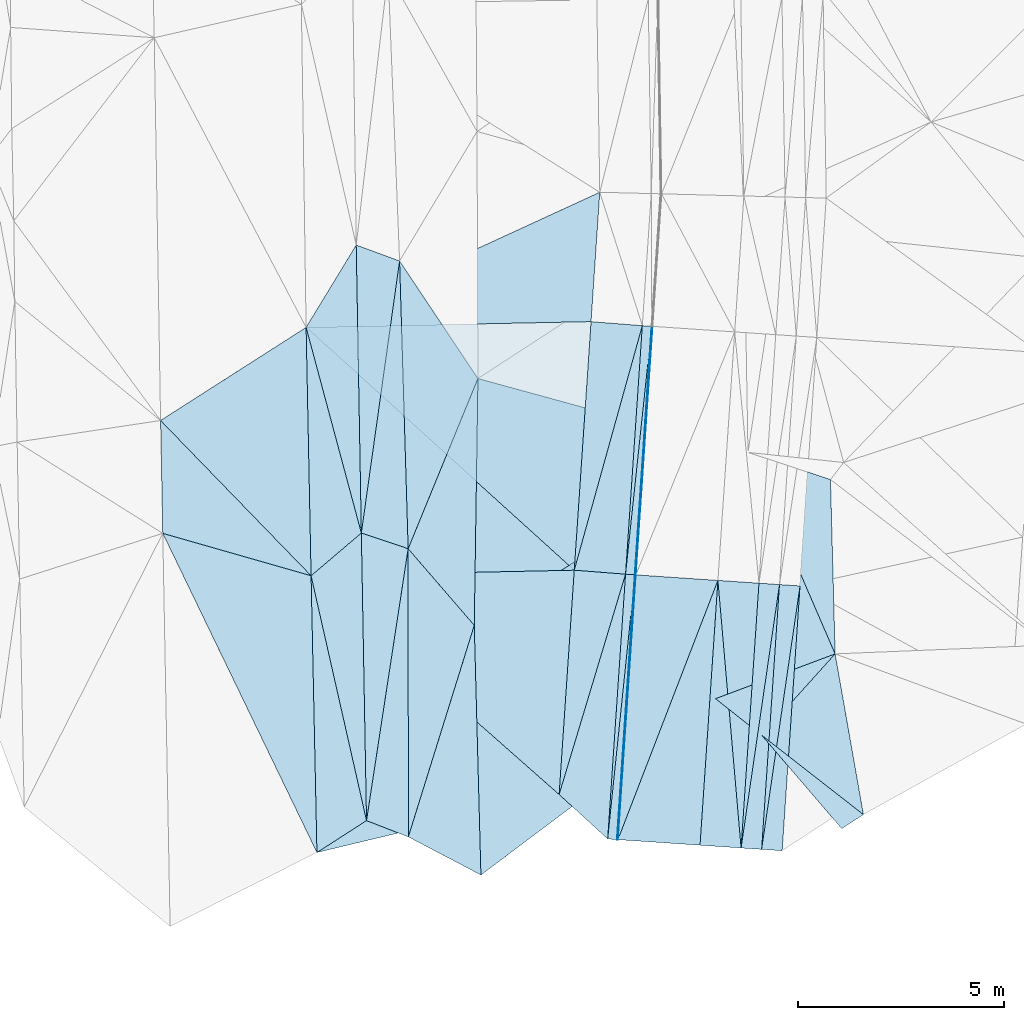
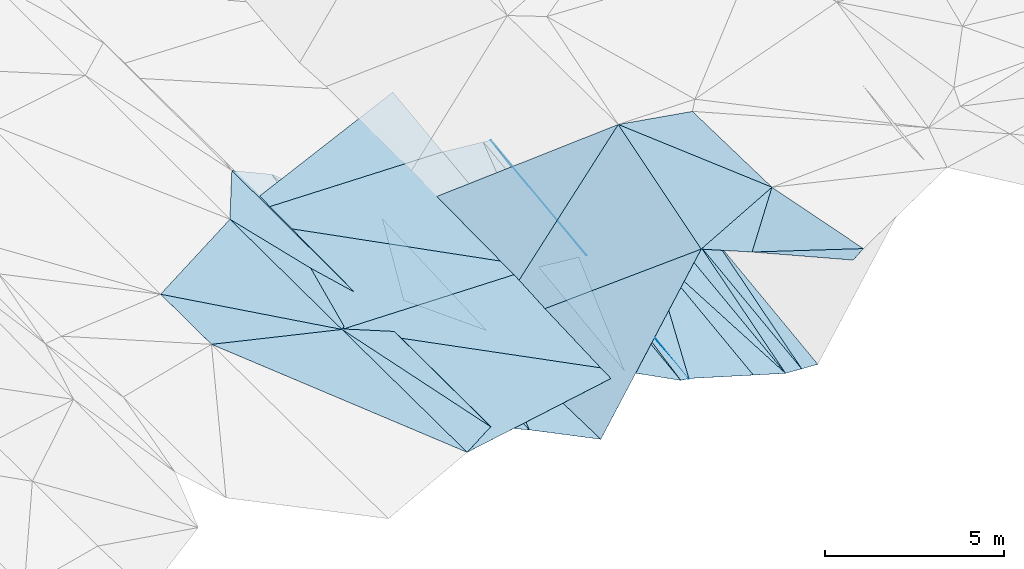
# One storey, part 24 of 275: 48 plates.
"""IFC2X3 building model written with IfcOpenShell, lengths in millimetres."""

from ifc_helpers import new_model, si_unit, frame, origin_with_axes, place, context, subcontext, project, spatial, polyline, outline, extrude, material, type_object, element, save


model = new_model("IFC2X3")

# Units and contexts
model_context = context("Model", 3, precision=1e-05, world=origin_with_axes())
body_context = subcontext(model_context, "Body", "Model", "MODEL_VIEW")
ifc_project = project(units=[si_unit("LENGTHUNIT", "METRE", prefix="MILLI"), si_unit("AREAUNIT", "SQUARE_METRE"), si_unit("VOLUMEUNIT", "CUBIC_METRE"), si_unit("MASSUNIT", "GRAM", prefix="KILO"), si_unit("TIMEUNIT", "SECOND"), si_unit("PLANEANGLEUNIT", "RADIAN"), si_unit("SOLIDANGLEUNIT", "STERADIAN"), si_unit("THERMODYNAMICTEMPERATUREUNIT", "DEGREE_CELSIUS"), si_unit("LUMINOUSINTENSITYUNIT", "LUMEN")], contexts=[model_context])

# Site, building, storey
site_placement = place(None, origin_with_axes())
site = spatial("IfcSite", under=ifc_project, at=site_placement, CompositionType="ELEMENT")
building_placement = place(site_placement, origin_with_axes())
building = spatial("IfcBuilding", under=site, at=building_placement, Name="Undefined", CompositionType="ELEMENT")
storey_placement = place(building_placement, origin_with_axes())
storey = spatial("IfcBuildingStorey", under=building, at=storey_placement, Name="Undefined", CompositionType="ELEMENT", Elevation=0.0)

# Plates
ifc_material = material()
plate_type_1 = type_object("IfcPlateType", PredefinedType="NOTDEFINED")
plate_1_placement = place(storey_placement, frame((-55994.0438618179, -20332.1473960006, 40503.9976994708), z_axis=(-0.0486226235014181, 0.0210317836379239, -0.998595766344344), x_axis=(0.0640764459747328, 0.997784539327098, 0.0178947520535479)))
element("IfcPlate", 1, at=plate_1_placement, inside=storey, type_object=plate_type_1, material=ifc_material, Name="00_PR", context=body_context, shape_type="SweptSolid", body=[
    extrude(outline(polyline([(0.0, 0.0), (6054.2333984375, -7.71979102864861e-09), (6054.1494140625, 20.0250854492188), (0.0, 0.0)])), frame((-8.85201319254618e-08, 2.18876761149539e-07, -0.5000001331573), z_axis=(0.0, 0.0, 1.0), x_axis=(1.0, 0.0, 0.0)), (0.0, 0.0, 1.0), 1.0),
])
plate_2_placement = place(storey_placement, frame((-56428.7011475439, -26767.9813575421, 40359.3747461236), z_axis=(-0.0483027016361894, 0.025700077195917, -0.998502055604679), x_axis=(0.064273337976945, 0.997677077378799, 0.0225696100586617)))
element("IfcPlate", 2, at=plate_2_placement, inside=storey, type_object=plate_type_1, material=ifc_material, Name="00_PR", context=body_context, shape_type="SweptSolid", body=[
    extrude(outline(polyline([(0.0, 0.0), (6452.171875, 1.65891833603382e-09), (6452.08740234375, 20.0250816345215), (0.0, 0.0)])), frame((-8.85201319254618e-08, 2.18876761149539e-07, -0.5000001331573), z_axis=(0.0, 0.0, 1.0), x_axis=(1.0, 0.0, 0.0)), (0.0, 0.0, 1.0), 1.0),
])
plate_3_placement = place(storey_placement, frame((-56013.9986952123, -20330.7999434034, 40504.9976994763), z_axis=(-0.0486226235014181, 0.0210317836379239, -0.998595766344344), x_axis=(0.0673730229281079, 0.997570314612421, 0.0177297260442445)))
element("IfcPlate", 3, at=plate_3_placement, inside=storey, type_object=plate_type_1, material=ifc_material, Name="00_PR", context=body_context, shape_type="SweptSolid", body=[
    extrude(outline(polyline([(0.0, 0.0), (6054.1826171875, -3.41970007866621e-09), (-0.0174913611263037, 20.0252532958984), (0.0, 0.0)])), frame((-8.85201319254618e-08, 2.18876761149539e-07, -0.5000001331573), z_axis=(0.0, 0.0, 1.0), x_axis=(1.0, 0.0, 0.0)), (0.0, 0.0, 1.0), 1.0),
])
plate_4_placement = place(storey_placement, frame((-56448.6559808388, -26766.6339047092, 40360.3747458464), z_axis=(-0.0483027016361894, 0.025700077195917, -0.998502055604679), x_axis=(0.0673666259477489, 0.99747647292743, 0.0224148090482824)))
element("IfcPlate", 4, at=plate_4_placement, inside=storey, type_object=plate_type_1, material=ifc_material, Name="00_PR", context=body_context, shape_type="SweptSolid", body=[
    extrude(outline(polyline([(0.0, 0.0), (6452.1181640625, -1.04555510915816e-08), (-0.0221778694540262, 20.0252475738525), (0.0, 0.0)])), frame((-8.85201319254618e-08, 2.18876761149539e-07, -0.5000001331573), z_axis=(0.0, 0.0, 1.0), x_axis=(1.0, 0.0, 0.0)), (0.0, 0.0, 1.0), 1.0),
])
plate_type_2 = type_object("IfcPlateType", PredefinedType="NOTDEFINED")
plate_5_placement = place(storey_placement, frame((-61735.0511576547, -12703.9562001124, 40635.5088356451), z_axis=(-0.186879824045943, 0.0118512076152222, -0.982311294978643), x_axis=(0.0297733535362695, -0.999399565842145, -0.0177216030238687)))
element("IfcPlate", 5, at=plate_5_placement, inside=storey, type_object=plate_type_2, material=ifc_material, Name="00", context=body_context, shape_type="SweptSolid", body=[
    extrude(outline(polyline([(0.0, 0.0), (6997.10986328125, 2.16823536902666e-09), (6577.8876953125, 1145.67492675781), (0.0, 0.0)])), frame((-8.85201319254618e-08, 2.18876761149539e-07, -0.5000001331573), z_axis=(0.0, 0.0, 1.0), x_axis=(1.0, 0.0, 0.0)), (0.0, 0.0, 1.0), 1.0),
])
plate_type_3 = type_object("IfcPlateType", PredefinedType="NOTDEFINED")
plate_6_placement = place(storey_placement, frame((-57857.8995234557, -25669.1794114902, 40434.7703518648), z_axis=(-0.0290497289859724, 0.0240139458065113, -0.999289469399455), x_axis=(0.0673673869295323, 0.997485387563912, 0.0220121960458264)))
element("IfcPlate", 6, at=plate_6_placement, inside=storey, type_object=plate_type_3, material=ifc_material, Name="00_PR", context=body_context, shape_type="SweptSolid", body=[
    extrude(outline(polyline([(0.0, 0.0), (5464.33447265625, -8.62200977280736e-09), (5450.97607421875, 1250.58508300781), (0.0, 0.0)])), frame((-8.85201319254618e-08, 2.18876761149539e-07, -0.5000001331573), z_axis=(0.0, 0.0, 1.0), x_axis=(1.0, 0.0, 0.0)), (0.0, 0.0, 1.0), 1.0),
])
plate_7_placement = place(storey_placement, frame((-62538.4169142698, -26304.1804412589, 40576.5003790668), z_axis=(-0.0329834993665363, 0.0215840583173638, -0.999222806583242), x_axis=(-0.840460606939976, -0.541635104646031, 0.0160431168159657)))
element("IfcPlate", 7, at=plate_7_placement, inside=storey, type_object=plate_type_3, material=ifc_material, Name="00", context=body_context, shape_type="SweptSolid", body=[
    extrude(outline(polyline([(0.0, 0.0), (1433.63659667969, -4.58385329693556e-09), (-2088.05078125, 5735.19140625), (0.0, 0.0)])), frame((-8.85201319254618e-08, 2.18876761149539e-07, -0.5000001331573), z_axis=(0.0, 0.0, 1.0), x_axis=(1.0, 0.0, 0.0)), (0.0, 0.0, 1.0), 1.0),
])
plate_type_4 = type_object("IfcPlateType", PredefinedType="NOTDEFINED")
for number, where, z_axis, x_axis, name in (
    (8, (-52003.1104330903, -20601.6807705177, 39753.9971245158), (0.00151039160382035, 0.0223638633050431, -0.999748756606017), (-0.0673666259495398, -0.997476472927282, -0.0224148090494552), "00_PR"),
    (9, (-52501.9738633444, -20567.9889643537, 39753.9971239012), (0.00151039160382035, 0.0223638633050431, -0.999748756606017), (-0.0673666259495398, -0.997476472927282, -0.0224148090494552), "00_PR"),
    (10, (-52936.6313090218, -27003.8252598671, 39609.3741236139), (0.00151039160382035, 0.0223638633050431, -0.999748756606017), (0.0673666259477489, 0.99747647292743, 0.0224148090482824), "00_PR"),
    (11, (-53435.4947396309, -26970.1334541876, 39609.374123206), (0.00151039160382035, 0.0223638633050431, -0.999748756606017), (0.0673666259477489, 0.99747647292743, 0.0224148090482824), "00_PR"),
):
    element("IfcPlate", number, at=place(storey_placement, frame(where, z_axis=z_axis, x_axis=x_axis)), inside=storey, type_object=plate_type_4, material=ifc_material, Name=name, context=body_context, shape_type="SweptSolid", body=[
        extrude(outline(polyline([(0.0, 0.0), (6452.1181640625, -1.04555510915816e-08), (6452.1181640625, 499.999847412109), (0.0, 0.0)])), frame((-8.85201319254618e-08, 2.18876761149539e-07, -0.5000001331573), z_axis=(0.0, 0.0, 1.0), x_axis=(1.0, 0.0, 0.0)), (0.0, 0.0, 1.0), 1.0),
    ])
plate_type_5 = type_object("IfcPlateType", PredefinedType="NOTDEFINED")
plate_8_placement = place(storey_placement, frame((-55606.1101103145, -14291.3270639496, 40612.336699794), z_axis=(-0.0486226235014181, 0.0210317836379239, -0.998595766344344), x_axis=(-0.0673730229274539, -0.997570314612598, -0.017729726036797)))
element("IfcPlate", 12, at=plate_8_placement, inside=storey, type_object=plate_type_5, material=ifc_material, Name="00_PR", context=body_context, shape_type="SweptSolid", body=[
    extrude(outline(polyline([(0.0, 0.0), (6054.1826171875, -3.41970007866621e-09), (6053.978515625, 230.287551879883), (0.0, 0.0)])), frame((-8.85201319254618e-08, 2.18876761149539e-07, -0.5000001331573), z_axis=(0.0, 0.0, 1.0), x_axis=(1.0, 0.0, 0.0)), (0.0, 0.0, 1.0), 1.0),
])
plate_9_placement = place(storey_placement, frame((-56013.9985354779, -20330.7976092791, 40504.9977462341), z_axis=(-0.0483027016361894, 0.025700077195917, -0.998502055604679), x_axis=(-0.0673666259495398, -0.997476472927282, -0.0224148090494552)))
element("IfcPlate", 13, at=plate_9_placement, inside=storey, type_object=plate_type_5, material=ifc_material, Name="00_PR", context=body_context, shape_type="SweptSolid", body=[
    extrude(outline(polyline([(0.0, 0.0), (6452.1181640625, -1.04555510915816e-08), (6451.8603515625, 230.287506103516), (0.0, 0.0)])), frame((-8.85201319254618e-08, 2.18876761149539e-07, -0.5000001331573), z_axis=(0.0, 0.0, 1.0), x_axis=(1.0, 0.0, 0.0)), (0.0, 0.0, 1.0), 1.0),
])
plate_10_placement = place(storey_placement, frame((-56243.4762379585, -20315.3012396831, 40516.4976988734), z_axis=(-0.0486226235014181, 0.0210317836379239, -0.998595766344344), x_axis=(0.0673730229281079, 0.997570314612421, 0.0177297260442445)))
element("IfcPlate", 14, at=plate_10_placement, inside=storey, type_object=plate_type_5, material=ifc_material, Name="00_PR", context=body_context, shape_type="SweptSolid", body=[
    extrude(outline(polyline([(0.0, 0.0), (6054.181640625, 3.7762220017612e-09), (6053.978515625, 230.287094116211), (0.0, 0.0)])), frame((-8.85201319254618e-08, 2.18876761149539e-07, -0.5000001331573), z_axis=(0.0, 0.0, 1.0), x_axis=(1.0, 0.0, 0.0)), (0.0, 0.0, 1.0), 1.0),
])
plate_11_placement = place(storey_placement, frame((-56678.1335236675, -26751.1351998631, 40371.8747453509), z_axis=(-0.0483027016361894, 0.025700077195917, -0.998502055604679), x_axis=(0.0673666259477489, 0.99747647292743, 0.0224148090482824)))
element("IfcPlate", 15, at=plate_11_placement, inside=storey, type_object=plate_type_5, material=ifc_material, Name="00_PR", context=body_context, shape_type="SweptSolid", body=[
    extrude(outline(polyline([(0.0, 0.0), (6452.1181640625, -1.04555510915816e-08), (6451.8603515625, 230.287506103516), (0.0, 0.0)])), frame((-8.85201319254618e-08, 2.18876761149539e-07, -0.5000001331573), z_axis=(0.0, 0.0, 1.0), x_axis=(1.0, 0.0, 0.0)), (0.0, 0.0, 1.0), 1.0),
])
plate_type_6 = type_object("IfcPlateType", PredefinedType="NOTDEFINED")
plate_12_placement = place(storey_placement, frame((-56243.4673122989, -20315.2994892361, 40516.4973840953), z_axis=(-0.0307722172408516, 0.0245323732293135, -0.999225316587715), x_axis=(-0.0673666259495398, -0.997476472927282, -0.0224148090494552)))
element("IfcPlate", 16, at=plate_12_placement, inside=storey, type_object=plate_type_6, material=ifc_material, Name="00_PR", context=body_context, shape_type="SweptSolid", body=[
    extrude(outline(polyline([(0.0, 0.0), (6452.1181640625, -1.04555510915816e-08), (5450.9599609375, 1250.65502929688), (0.0, 0.0)])), frame((-8.85201319254618e-08, 2.18876761149539e-07, -0.5000001331573), z_axis=(0.0, 0.0, 1.0), x_axis=(1.0, 0.0, 0.0)), (0.0, 0.0, 1.0), 1.0),
])
plate_type_7 = type_object("IfcPlateType", PredefinedType="NOTDEFINED")
plate_13_placement = place(storey_placement, frame((-55835.5776282148, -14275.8299167831, 40623.8363105388), z_axis=(-0.0293834917019971, 0.0197462494133177, -0.999373151555267), x_axis=(-0.0673730229274539, -0.997570314612598, -0.017729726036797)))
element("IfcPlate", 17, at=plate_13_placement, inside=storey, type_object=plate_type_7, material=ifc_material, Name="00_PR", context=body_context, shape_type="SweptSolid", body=[
    extrude(outline(polyline([(0.0, 0.0), (6054.181640625, 3.7762220017612e-09), (6040.9873046875, 1250.58679199219), (0.0, 0.0)])), frame((-8.85201319254618e-08, 2.18876761149539e-07, -0.5000001331573), z_axis=(0.0, 0.0, 1.0), x_axis=(1.0, 0.0, 0.0)), (0.0, 0.0, 1.0), 1.0),
])
plate_14_placement = place(storey_placement, frame((-57489.7820643485, -20218.587643262, 40555.0523211425), z_axis=(-0.0300018392704809, 0.0199181181668372, -0.999351368743287), x_axis=(0.0673728319244104, 0.997568004496844, 0.0178599530422175)))
element("IfcPlate", 18, at=plate_14_placement, inside=storey, type_object=plate_type_7, material=ifc_material, Name="00_PR", context=body_context, shape_type="SweptSolid", body=[
    extrude(outline(polyline([(0.0, 0.0), (6055.05517578125, -8.69476934894919e-09), (6040.98193359375, 1250.61181640625), (0.0, 0.0)])), frame((-8.85201319254618e-08, 2.18876761149539e-07, -0.5000001331573), z_axis=(0.0, 0.0, 1.0), x_axis=(1.0, 0.0, 0.0)), (0.0, 0.0, 1.0), 1.0),
])
plate_type_8 = type_object("IfcPlateType", PredefinedType="NOTDEFINED")
plate_15_placement = place(storey_placement, frame((-53000.9582804916, -20534.2893235996, 39754.0120413405), z_axis=(-0.24046190228031, 0.0380355070283578, -0.969913075361308), x_axis=(-0.0673666259495398, -0.997476472927282, -0.0224148090494552)))
element("IfcPlate", 19, at=plate_15_placement, inside=storey, type_object=plate_type_8, material=ifc_material, Name="00_PR", context=body_context, shape_type="SweptSolid", body=[
    extrude(outline(polyline([(0.0, 0.0), (6452.1181640625, -1.04555510915816e-08), (-5.60377645492554, 1030.76086425781), (0.0, 0.0)])), frame((-8.85201319254618e-08, 2.18876761149539e-07, -0.5000001331573), z_axis=(0.0, 0.0, 1.0), x_axis=(1.0, 0.0, 0.0)), (0.0, 0.0, 1.0), 1.0),
])
plate_16_placement = place(storey_placement, frame((-54433.343502675, -26902.7424122213, 39859.3890407221), z_axis=(-0.24046190228031, 0.0380355070283578, -0.969913075361308), x_axis=(0.0673666259477489, 0.99747647292743, 0.0224148090482824)))
element("IfcPlate", 20, at=plate_16_placement, inside=storey, type_object=plate_type_8, material=ifc_material, Name="00_PR", context=body_context, shape_type="SweptSolid", body=[
    extrude(outline(polyline([(0.0, 0.0), (6452.11865234375, -4.26371116191149e-09), (-5.60317373275757, 1030.76171875), (0.0, 0.0)])), frame((-8.85201319254618e-08, 2.18876761149539e-07, -0.5000001331573), z_axis=(0.0, 0.0, 1.0), x_axis=(1.0, 0.0, 0.0)), (0.0, 0.0, 1.0), 1.0),
])
plate_type_9 = type_object("IfcPlateType", PredefinedType="NOTDEFINED")
plate_17_placement = place(storey_placement, frame((-63885.4729191214, -20353.7279276687, 40749.5003695473), z_axis=(-0.0323781670630732, 0.0217215821235187, -0.999239624498392), x_axis=(0.761781970801217, 0.647746712532554, -0.0106030828291486)))
element("IfcPlate", 21, at=plate_17_placement, inside=storey, type_object=plate_type_9, material=ifc_material, Name="00", context=body_context, shape_type="SweptSolid", body=[
    extrude(outline(polyline([(0.0, 0.0), (1603.30725097656, 1.78624759428203e-09), (-2826.38842773438, 5409.61181640625), (0.0, 0.0)])), frame((-8.85201319254618e-08, 2.18876761149539e-07, -0.5000001331573), z_axis=(0.0, 0.0, 1.0), x_axis=(1.0, 0.0, 0.0)), (0.0, 0.0, 1.0), 1.0),
])
plate_type_10 = type_object("IfcPlateType", PredefinedType="NOTDEFINED")
plate_18_placement = place(storey_placement, frame((-55994.1397812557, -20332.1388939847, 40504.0120409392), z_axis=(-0.24046190228031, 0.0380355070283578, -0.969913075361308), x_axis=(0.967937486368815, -0.0653717219691512, -0.242535689020827)))
element("IfcPlate", 22, at=plate_18_placement, inside=storey, type_object=plate_type_10, material=ifc_material, Name="00_PR", context=body_context, shape_type="SweptSolid", body=[
    extrude(outline(polyline([(0.0, 0.0), (2061.55322265625, 1.61162461154163e-09), (35.0752372741699, 6452.02294921875), (0.0, 0.0)])), frame((-8.85201319254618e-08, 2.18876761149539e-07, -0.5000001331573), z_axis=(0.0, 0.0, 1.0), x_axis=(1.0, 0.0, 0.0)), (0.0, 0.0, 1.0), 1.0),
])
plate_19_placement = place(storey_placement, frame((-53998.685141977, -20466.9057129648, 40004.012041129), z_axis=(-0.24046190228031, 0.0380355070283578, -0.969913075361308), x_axis=(-0.0673666259495398, -0.997476472927282, -0.0224148090494552)))
element("IfcPlate", 23, at=plate_19_placement, inside=storey, type_object=plate_type_10, material=ifc_material, Name="00_PR", context=body_context, shape_type="SweptSolid", body=[
    extrude(outline(polyline([(0.0, 0.0), (6452.11865234375, -4.26371116191149e-09), (6440.91162109375, 2061.52172851563), (0.0, 0.0)])), frame((-8.85201319254618e-08, 2.18876761149539e-07, -0.5000001331573), z_axis=(0.0, 0.0, 1.0), x_axis=(1.0, 0.0, 0.0)), (0.0, 0.0, 1.0), 1.0),
])
plate_type_11 = type_object("IfcPlateType", PredefinedType="NOTDEFINED")
plate_20_placement = place(storey_placement, frame((-64006.6315311768, -14317.2471178502, 40878.3563292507), z_axis=(-0.0314219059164073, 0.0185078624214838, -0.999334840209811), x_axis=(0.908266557760753, 0.417873681937883, -0.0208193659151763)))
element("IfcPlate", 24, at=plate_20_placement, inside=storey, type_object=plate_type_11, material=ifc_material, Name="00_PR", context=body_context, shape_type="SweptSolid", body=[
    extrude(outline(polyline([(0.0, 0.0), (7858.02001953125, 2.17332853935659e-08), (6352.11865234375, 2769.29345703125), (0.0, 0.0)])), frame((-8.85201319254618e-08, 2.18876761149539e-07, -0.5000001331573), z_axis=(0.0, 0.0, 1.0), x_axis=(1.0, 0.0, 0.0)), (0.0, 0.0, 1.0), 1.0),
])
plate_type_12 = type_object("IfcPlateType", PredefinedType="NOTDEFINED")
plate_21_placement = place(storey_placement, frame((-64006.6315460439, -14317.2463642798, 40878.3563441201), z_axis=(-0.0314512282477183, 0.0200151724602033, -0.99930486495018), x_axis=(0.999316570569513, 0.0200573580357693, -0.0310498659226219)))
element("IfcPlate", 25, at=plate_21_placement, inside=storey, type_object=plate_type_12, material=ifc_material, Name="00_PR", context=body_context, shape_type="SweptSolid", body=[
    extrude(outline(polyline([(0.0, 0.0), (6929.53076171875, -9.10586095415056e-09), (6404.068359375, 6032.2119140625), (0.0, 0.0)])), frame((-8.85201319254618e-08, 2.18876761149539e-07, -0.5000001331573), z_axis=(0.0, 0.0, 1.0), x_axis=(1.0, 0.0, 0.0)), (0.0, 0.0, 1.0), 1.0),
])
plate_type_13 = type_object("IfcPlateType", PredefinedType="NOTDEFINED")
plate_22_placement = place(storey_placement, frame((-57857.9014544586, -25669.1804967518, 40434.7703865658), z_axis=(-0.0329111902445832, 0.0218438241486999, -0.99921954589732), x_axis=(-0.972072186816292, -0.233132897000999, 0.0269205489192627)))
element("IfcPlate", 26, at=plate_22_placement, inside=storey, type_object=plate_type_13, material=ifc_material, Name="00_PR", context=body_context, shape_type="SweptSolid", body=[
    extrude(outline(polyline([(0.0, 0.0), (6054.52001953125, -7.53061613067985e-10), (4628.50048828125, 6577.3623046875), (0.0, 0.0)])), frame((-8.85201319254618e-08, 2.18876761149539e-07, -0.5000001331573), z_axis=(0.0, 0.0, 1.0), x_axis=(1.0, 0.0, 0.0)), (0.0, 0.0, 1.0), 1.0),
])
plate_type_14 = type_object("IfcPlateType", PredefinedType="NOTDEFINED")
plate_23_placement = place(storey_placement, frame((-63885.4721199596, -20353.726761158, 40749.5003806365), z_axis=(-0.0308896203677553, 0.0241369235080948, -0.999231324707698), x_axis=(0.999315293937877, 0.0211155800413339, -0.0303821589320439)))
element("IfcPlate", 27, at=plate_23_placement, inside=storey, type_object=plate_type_14, material=ifc_material, Name="00_PR", context=body_context, shape_type="SweptSolid", body=[
    extrude(outline(polyline([(0.0, 0.0), (6400.07177734375, -2.16132320929319e-08), (5920.76806640625, 5443.27294921875), (0.0, 0.0)])), frame((-8.85201319254618e-08, 2.18876761149539e-07, -0.5000001331573), z_axis=(0.0, 0.0, 1.0), x_axis=(1.0, 0.0, 0.0)), (0.0, 0.0, 1.0), 1.0),
])
plate_type_15 = type_object("IfcPlateType", PredefinedType="NOTDEFINED")
plate_24_placement = place(storey_placement, frame((-57489.7824733442, -20218.5872458798, 40555.052341731), z_axis=(-0.0308196723650857, 0.0207128980589162, -0.999310323998161), x_axis=(-0.999315293937734, -0.021115580040059, 0.030382158937659)))
element("IfcPlate", 28, at=plate_24_placement, inside=storey, type_object=plate_type_15, material=ifc_material, Name="00_PR", context=body_context, shape_type="SweptSolid", body=[
    extrude(outline(polyline([(0.0, 0.0), (6400.07177734375, -2.16132320929319e-08), (6397.59912109375, 6039.07275390625), (0.0, 0.0)])), frame((-8.85201319254618e-08, 2.18876761149539e-07, -0.5000001331573), z_axis=(0.0, 0.0, 1.0), x_axis=(1.0, 0.0, 0.0)), (0.0, 0.0, 1.0), 1.0),
])
plate_type_16 = type_object("IfcPlateType", PredefinedType="NOTDEFINED")
plate_25_placement = place(storey_placement, frame((-50462.3365093103, -26157.8882280428, 42319.5049470986), z_axis=(0.0765274628669454, -0.117786381280091, -0.990085812347642), x_axis=(-0.838553180378593, -0.544819753383582, -1.74144427581193e-10)))
element("IfcPlate", 29, at=plate_25_placement, inside=storey, type_object=plate_type_16, material=ifc_material, Name="00", context=body_context, shape_type="SweptSolid", body=[
    extrude(outline(polyline([(0.0, 0.0), (628.012756347656, 1.43973011290655e-09), (1021.63531494141, 2990.09375), (0.0, 0.0)])), frame((-8.85201319254618e-08, 2.18876761149539e-07, -0.5000001331573), z_axis=(0.0, 0.0, 1.0), x_axis=(1.0, 0.0, 0.0)), (0.0, 0.0, 1.0), 1.0),
])
plate_type_17 = type_object("IfcPlateType", PredefinedType="NOTDEFINED")
plate_26_placement = place(storey_placement, frame((-61735.0595186344, -12703.9564787346, 40635.5104970733), z_axis=(-0.203601674780514, 0.0112941252416546, -0.978988662223213), x_axis=(0.550510839357867, -0.825565366536387, -0.124014681893467)))
element("IfcPlate", 30, at=plate_26_placement, inside=storey, type_object=plate_type_17, material=ifc_material, Name="00", context=body_context, shape_type="SweptSolid", body=[
    extrude(outline(polyline([(0.0, 0.0), (3459.26782226563, 4.20550350099802e-09), (5903.16748046875, 3756.61547851563), (0.0, 0.0)])), frame((-8.85201319254618e-08, 2.18876761149539e-07, -0.5000001331573), z_axis=(0.0, 0.0, 1.0), x_axis=(1.0, 0.0, 0.0)), (0.0, 0.0, 1.0), 1.0),
])
plate_type_18 = type_object("IfcPlateType", PredefinedType="NOTDEFINED")
plate_27_placement = place(storey_placement, frame((-59830.7159885937, -15559.7992528572, 40206.5155022642), z_axis=(-0.245417871408709, 0.0291751922989391, -0.968978264228635), x_axis=(-0.0148720074543326, -0.999542705389004, -0.0263287580016239)))
element("IfcPlate", 31, at=plate_27_placement, inside=storey, type_object=plate_type_18, material=ifc_material, Name="00", context=body_context, shape_type="SweptSolid", body=[
    extrude(outline(polyline([(0.0, 0.0), (6001.04248046875, 2.64844857156277e-09), (4152.35791015625, 1686.03894042969), (0.0, 0.0)])), frame((-8.85201319254618e-08, 2.18876761149539e-07, -0.5000001331573), z_axis=(0.0, 0.0, 1.0), x_axis=(1.0, 0.0, 0.0)), (0.0, 0.0, 1.0), 1.0),
])
plate_type_19 = type_object("IfcPlateType", PredefinedType="NOTDEFINED")
plate_28_placement = place(storey_placement, frame((-62664.1020375691, -19315.19137287, 40732.5003505537), z_axis=(-0.0316670650693428, 0.0208846260861512, -0.999280255675622), x_axis=(-0.761781970800384, -0.64774671253308, 0.0106030828569081)))
element("IfcPlate", 32, at=plate_28_placement, inside=storey, type_object=plate_type_19, material=ifc_material, Name="00", context=body_context, shape_type="SweptSolid", body=[
    extrude(outline(polyline([(0.0, 0.0), (1603.30725097656, 1.78624759428203e-09), (-2213.12915039063, 4680.33251953125), (0.0, 0.0)])), frame((-8.85201319254618e-08, 2.18876761149539e-07, -0.5000001331573), z_axis=(0.0, 0.0, 1.0), x_axis=(1.0, 0.0, 0.0)), (0.0, 0.0, 1.0), 1.0),
])
plate_type_20 = type_object("IfcPlateType", PredefinedType="NOTDEFINED")
plate_29_placement = place(storey_placement, frame((-62538.4927645033, -26304.1819284656, 40576.5086788765), z_axis=(-0.184672032931403, 0.0186119457391196, -0.982623954383765), x_axis=(-0.0179760145432033, 0.999589442085032, 0.0223116600296301)))
element("IfcPlate", 33, at=plate_29_placement, inside=storey, type_object=plate_type_20, material=ifc_material, Name="00", context=body_context, shape_type="SweptSolid", body=[
    extrude(outline(polyline([(0.0, 0.0), (6991.85986328125, 8.00355337560177e-09), (6584.97021484375, 1150.11242675781), (0.0, 0.0)])), frame((-8.85201319254618e-08, 2.18876761149539e-07, -0.5000001331573), z_axis=(0.0, 0.0, 1.0), x_axis=(1.0, 0.0, 0.0)), (0.0, 0.0, 1.0), 1.0),
])
plate_type_21 = type_object("IfcPlateType", PredefinedType="NOTDEFINED")
plate_30_placement = place(storey_placement, frame((-51150.164550694, -22252.4210056617, 42279.5051491622), z_axis=(0.112531364993902, 0.0886976706104643, -0.989681471545713), x_axis=(-0.66230514815091, -0.735798868059881, -0.141251253072672)))
element("IfcPlate", 34, at=plate_30_placement, inside=storey, type_object=plate_type_21, material=ifc_material, Name="00", context=body_context, shape_type="SweptSolid", body=[
    extrude(outline(polyline([(0.0, 0.0), (2690.24169921875, -1.92449078895152e-09), (2786.244140625, 1431.66772460938), (0.0, 0.0)])), frame((-8.85201319254618e-08, 2.18876761149539e-07, -0.5000001331573), z_axis=(0.0, 0.0, 1.0), x_axis=(1.0, 0.0, 0.0)), (0.0, 0.0, 1.0), 1.0),
])
plate_type_22 = type_object("IfcPlateType", PredefinedType="NOTDEFINED")
plate_31_placement = place(storey_placement, frame((-53267.9169250221, -17355.6423568107, 42185.5227272645), z_axis=(0.297776317370575, 0.0140617619377745, -0.954532100908306), x_axis=(-0.130318059473388, -0.989932340326694, -0.0552373510444235)))
element("IfcPlate", 35, at=plate_31_placement, inside=storey, type_object=plate_type_22, material=ifc_material, Name="00", context=body_context, shape_type="SweptSolid", body=[
    extrude(outline(polyline([(0.0, 0.0), (6046.63330078125, 5.44969225302339e-09), (5145.04248046875, 6324.72216796875), (0.0, 0.0)])), frame((-8.85201319254618e-08, 2.18876761149539e-07, -0.5000001331573), z_axis=(0.0, 0.0, 1.0), x_axis=(1.0, 0.0, 0.0)), (0.0, 0.0, 1.0), 1.0),
])
plate_type_23 = type_object("IfcPlateType", PredefinedType="NOTDEFINED")
plate_32_placement = place(storey_placement, frame((-61522.6125860228, -26700.2314293747, 40354.5107636336), z_axis=(-0.205314557263015, 0.0218139403210576, -0.978452903610369), x_axis=(-0.912969063067592, 0.355926557492148, 0.199508835777445)))
element("IfcPlate", 36, at=plate_32_placement, inside=storey, type_object=plate_type_23, material=ifc_material, Name="00", context=body_context, shape_type="SweptSolid", body=[
    extrude(outline(polyline([(0.0, 0.0), (1112.73266601563, 3.11410985887051e-09), (2527.77075195313, 6533.166015625), (0.0, 0.0)])), frame((-8.85201319254618e-08, 2.18876761149539e-07, -0.5000001331573), z_axis=(0.0, 0.0, 1.0), x_axis=(1.0, 0.0, 0.0)), (0.0, 0.0, 1.0), 1.0),
])
plate_type_24 = type_object("IfcPlateType", PredefinedType="NOTDEFINED")
plate_33_placement = place(storey_placement, frame((-67489.9649031771, -19323.1803298745, 40879.5003255943), z_axis=(-0.0298510017294526, 0.0216524113241711, -0.999319814063344), x_axis=(0.960897593021636, -0.274726754307865, -0.0346558248017974)))
element("IfcPlate", 37, at=plate_33_placement, inside=storey, type_object=plate_type_24, material=ifc_material, Name="00", context=body_context, shape_type="SweptSolid", body=[
    extrude(outline(polyline([(0.0, 0.0), (3751.17309570313, 1.41444616019726e-08), (5741.03076171875, 6429.2431640625), (0.0, 0.0)])), frame((-8.85201319254618e-08, 2.18876761149539e-07, -0.5000001331573), z_axis=(0.0, 0.0, 1.0), x_axis=(1.0, 0.0, 0.0)), (0.0, 0.0, 1.0), 1.0),
])
plate_type_25 = type_object("IfcPlateType", PredefinedType="NOTDEFINED")
plate_34_placement = place(storey_placement, frame((-51150.1827230467, -22252.4584621339, 42279.501487637), z_axis=(0.0761354728998192, 0.0137895577461905, -0.9970021253054), x_axis=(-0.39689738668073, 0.917693921939979, -0.0176161880220069)))
element("IfcPlate", 38, at=plate_34_placement, inside=storey, type_object=plate_type_25, material=ifc_material, Name="00", context=body_context, shape_type="SweptSolid", body=[
    extrude(outline(polyline([(0.0, 0.0), (5336.00146484375, -2.08092387765646e-09), (3931.35766601563, 1582.85388183594), (0.0, 0.0)])), frame((-8.85201319254618e-08, 2.18876761149539e-07, -0.5000001331573), z_axis=(0.0, 0.0, 1.0), x_axis=(1.0, 0.0, 0.0)), (0.0, 0.0, 1.0), 1.0),
])
plate_type_26 = type_object("IfcPlateType", PredefinedType="NOTDEFINED")
plate_35_placement = place(storey_placement, frame((-62664.2031603828, -19315.1925043706, 40732.513948524), z_axis=(-0.233891850978939, 0.0186082166088515, -0.972084531468475), x_axis=(-0.0178159005582707, 0.999566932409744, 0.0234209589955756)))
element("IfcPlate", 39, at=plate_35_placement, inside=storey, type_object=plate_type_26, material=ifc_material, Name="00", context=body_context, shape_type="SweptSolid", body=[
    extrude(outline(polyline([(0.0, 0.0), (7002.27490234375, 1.07247615233064e-08), (6589.55126953125, 1076.56408691406), (0.0, 0.0)])), frame((-8.85201319254618e-08, 2.18876761149539e-07, -0.5000001331573), z_axis=(0.0, 0.0, 1.0), x_axis=(1.0, 0.0, 0.0)), (0.0, 0.0, 1.0), 1.0),
])
plate_type_27 = type_object("IfcPlateType", PredefinedType="NOTDEFINED")
plate_36_placement = place(storey_placement, frame((-67543.4706653879, -16580.6201914766, 40939.5003233009), z_axis=(-0.029958186527795, 0.0212781261204577, -0.999324646152975), x_axis=(0.695615594654701, -0.717505051704967, -0.0361309458918571)))
element("IfcPlate", 40, at=plate_36_placement, inside=storey, type_object=plate_type_27, material=ifc_material, Name="00", context=body_context, shape_type="SweptSolid", body=[
    extrude(outline(polyline([(0.0, 0.0), (5258.64990234375, -1.94486347027123e-08), (2007.18811035156, 1870.64050292969), (0.0, 0.0)])), frame((-8.85201319254618e-08, 2.18876761149539e-07, -0.5000001331573), z_axis=(0.0, 0.0, 1.0), x_axis=(1.0, 0.0, 0.0)), (0.0, 0.0, 1.0), 1.0),
])
plate_type_28 = type_object("IfcPlateType", PredefinedType="NOTDEFINED")
plate_37_placement = place(storey_placement, frame((-50462.2824684523, -26157.8181092994, 42319.5087123459), z_axis=(0.184609124347929, 0.022451283328317, -0.982555551144261), x_axis=(-0.781568140526107, 0.609494610605839, -0.132919379162711)))
element("IfcPlate", 41, at=plate_37_placement, inside=storey, type_object=plate_type_28, material=ifc_material, Name="00", context=body_context, shape_type="SweptSolid", body=[
    extrude(outline(polyline([(0.0, 0.0), (3159.81005859375, -3.36149241775274e-09), (2923.21362304688, 2679.81762695313), (0.0, 0.0)])), frame((-8.85201319254618e-08, 2.18876761149539e-07, -0.5000001331573), z_axis=(0.0, 0.0, 1.0), x_axis=(1.0, 0.0, 0.0)), (0.0, 0.0, 1.0), 1.0),
])
plate_type_29 = type_object("IfcPlateType", PredefinedType="NOTDEFINED")
plate_38_placement = place(storey_placement, frame((-54055.9854579033, -23341.3881652687, 41851.5047064395), z_axis=(0.131683679731125, 0.0379373977467707, -0.9905655770037), x_axis=(0.130318059372214, 0.989932340338779, 0.055237351066533)))
element("IfcPlate", 42, at=plate_38_placement, inside=storey, type_object=plate_type_29, material=ifc_material, Name="00", context=body_context, shape_type="SweptSolid", body=[
    extrude(outline(polyline([(0.0, 0.0), (6046.63330078125, 5.44969225302339e-09), (1480.30249023438, 2760.71240234375), (0.0, 0.0)])), frame((-8.85201319254618e-08, 2.18876761149539e-07, -0.5000001331573), z_axis=(0.0, 0.0, 1.0), x_axis=(1.0, 0.0, 0.0)), (0.0, 0.0, 1.0), 1.0),
])
plate_type_30 = type_object("IfcPlateType", PredefinedType="NOTDEFINED")
plate_39_placement = place(storey_placement, frame((-64006.6310439696, -14317.2458684149, 40879.5003258907), z_axis=(-0.030335404943913, 0.0209122313953678, -0.999320990365436), x_axis=(0.0200624586798335, -0.999566962273141, -0.0215263950480792)))
element("IfcPlate", 43, at=plate_39_placement, inside=storey, type_object=plate_type_30, material=ifc_material, Name="00", context=body_context, shape_type="SweptSolid", body=[
    extrude(outline(polyline([(0.0, 0.0), (6039.09765625, 2.84489942714572e-09), (2190.14501953125, 3583.15014648438), (0.0, 0.0)])), frame((-8.85201319254618e-08, 2.18876761149539e-07, -0.5000001331573), z_axis=(0.0, 0.0, 1.0), x_axis=(1.0, 0.0, 0.0)), (0.0, 0.0, 1.0), 1.0),
])
plate_type_31 = type_object("IfcPlateType", PredefinedType="NOTDEFINED")
plate_40_placement = place(storey_placement, frame((-64006.6277956276, -14317.2448341933, 40879.5002640415), z_axis=(-0.0238352154105477, 0.0229934237592184, -0.999451442027156), x_axis=(0.519807731648981, 0.85425246045557, 0.00725644014278299)))
element("IfcPlate", 44, at=plate_40_placement, inside=storey, type_object=plate_type_31, material=ifc_material, Name="00", context=body_context, shape_type="SweptSolid", body=[
    extrude(outline(polyline([(0.0, 0.0), (2342.74658203125, -1.4915713109076e-09), (-3572.71655273438, 3746.88525390625), (0.0, 0.0)])), frame((-8.85201319254618e-08, 2.18876761149539e-07, -0.5000001331573), z_axis=(0.0, 0.0, 1.0), x_axis=(1.0, 0.0, 0.0)), (0.0, 0.0, 1.0), 1.0),
])
plate_type_32 = type_object("IfcPlateType", PredefinedType="NOTDEFINED")
plate_41_placement = place(storey_placement, frame((-59919.9676877919, -21558.1014904819, 40048.5164726652), z_axis=(-0.253715500028038, 0.0215295949039236, -0.967039255453881), x_axis=(-0.297077571581273, -0.953167137489404, 0.0567214639588068)))
element("IfcPlate", 45, at=plate_41_placement, inside=storey, type_object=plate_type_32, material=ifc_material, Name="00", context=body_context, shape_type="SweptSolid", body=[
    extrude(outline(polyline([(0.0, 0.0), (5394.783203125, -7.38509697839618e-09), (-1270.47131347656, 2155.51953125), (0.0, 0.0)])), frame((-8.85201319254618e-08, 2.18876761149539e-07, -0.5000001331573), z_axis=(0.0, 0.0, 1.0), x_axis=(1.0, 0.0, 0.0)), (0.0, 0.0, 1.0), 1.0),
])
plate_type_33 = type_object("IfcPlateType", PredefinedType="NOTDEFINED")
plate_42_placement = place(storey_placement, frame((-59919.6912722316, -21558.102768063, 40048.5229782207), z_axis=(0.299115384421914, 0.0189742347635277, -0.954028283237593), x_axis=(0.917843409559937, -0.279134414624875, 0.282218805361052)))
element("IfcPlate", 46, at=plate_42_placement, inside=storey, type_object=plate_type_33, material=ifc_material, Name="00", context=body_context, shape_type="SweptSolid", body=[
    extrude(outline(polyline([(0.0, 0.0), (6388.66015625, -1.07756932266057e-08), (1822.69360351563, 5791.35400390625), (0.0, 0.0)])), frame((-8.85201319254618e-08, 2.18876761149539e-07, -0.5000001331573), z_axis=(0.0, 0.0, 1.0), x_axis=(1.0, 0.0, 0.0)), (0.0, 0.0, 1.0), 1.0),
])
plate_type_34 = type_object("IfcPlateType", PredefinedType="NOTDEFINED")
plate_43_placement = place(storey_placement, frame((-59919.6938912693, -21558.1018580556, 40048.5221820783), z_axis=(0.293868945055795, 0.0207993621214565, -0.955619395819871), x_axis=(0.014872007448298, 0.999542705388798, 0.0263287580128583)))
element("IfcPlate", 47, at=plate_43_placement, inside=storey, type_object=plate_type_34, material=ifc_material, Name="00", context=body_context, shape_type="SweptSolid", body=[
    extrude(outline(polyline([(0.0, 0.0), (6001.04248046875, 2.64844857156277e-09), (4355.73095703125, 6892.1103515625), (0.0, 0.0)])), frame((-8.85201319254618e-08, 2.18876761149539e-07, -0.5000001331573), z_axis=(0.0, 0.0, 1.0), x_axis=(1.0, 0.0, 0.0)), (0.0, 0.0, 1.0), 1.0),
])
plate_type_35 = type_object("IfcPlateType", PredefinedType="NOTDEFINED")
plate_44_placement = place(storey_placement, frame((-59758.2340438456, -27626.9594967253, 39978.5106710878), z_axis=(-0.205501364966936, 0.00581217912824583, -0.978639569796004), x_axis=(-0.869963283196722, 0.456938446439739, 0.185394557781016)))
element("IfcPlate", 48, at=plate_44_placement, inside=storey, type_object=plate_type_35, material=ifc_material, Name="00", context=body_context, shape_type="SweptSolid", body=[
    extrude(outline(polyline([(0.0, 0.0), (2028.10705566406, 2.47382558882236e-09), (2926.75, 5319.41015625), (0.0, 0.0)])), frame((-8.85201319254618e-08, 2.18876761149539e-07, -0.5000001331573), z_axis=(0.0, 0.0, 1.0), x_axis=(1.0, 0.0, 0.0)), (0.0, 0.0, 1.0), 1.0),
])

save(model, "model.ifc")
